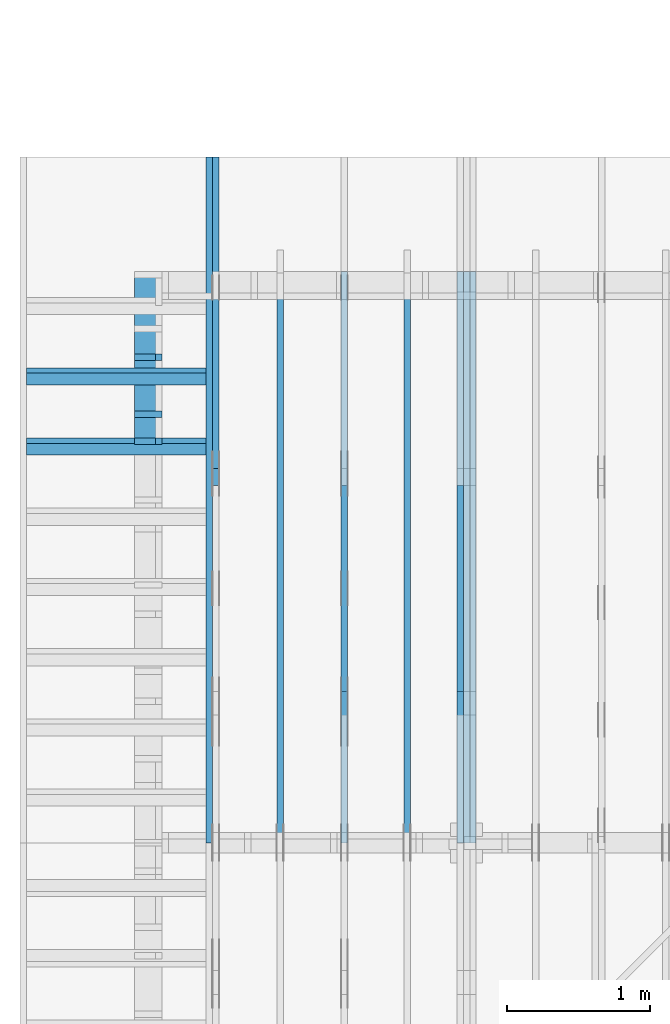
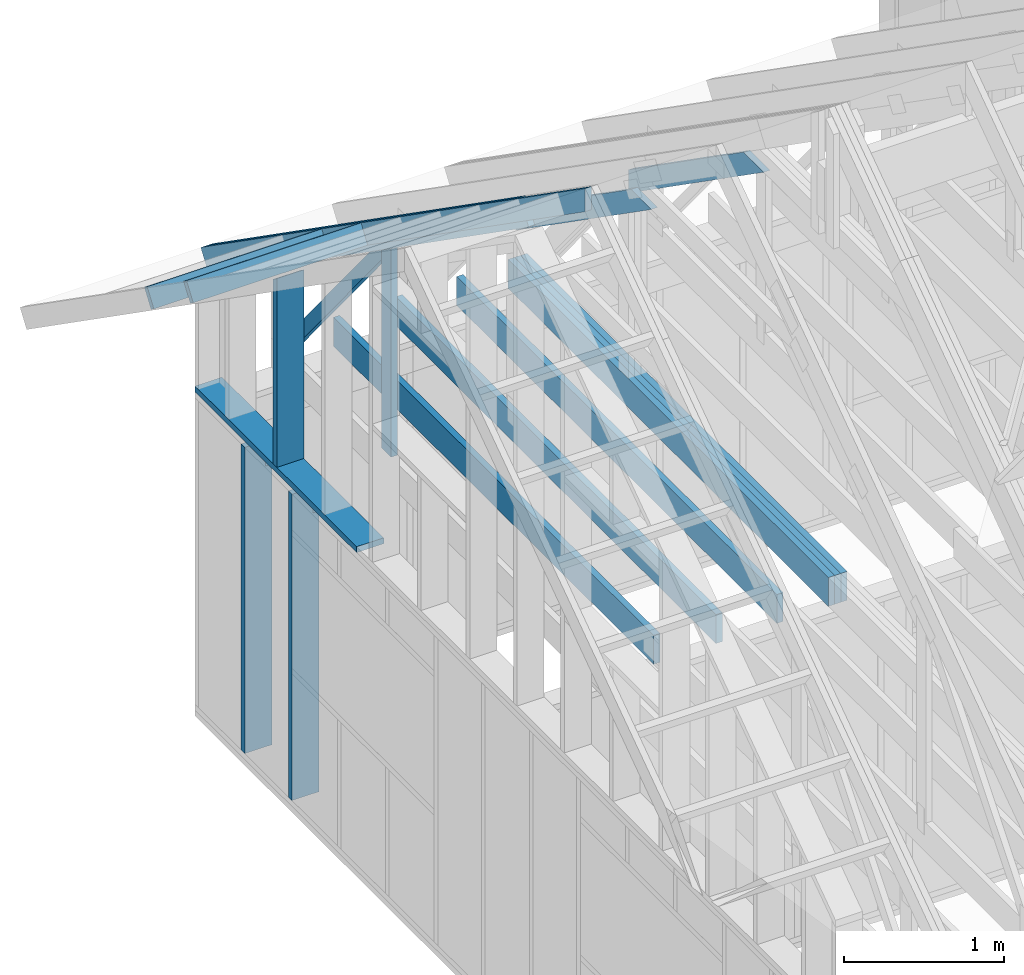
# One storey, part 13 of 70: 18 members, 8 elements without a shape of their own.
"""IFC2X3 building model written with IfcOpenShell, lengths in millimetres."""

from ifc_helpers import new_model, si_unit, frame, origin, origin_with_axes, origin_2d, place, context, project, spatial, faceted_brep, element, aggregate, save


model = new_model("IFC2X3")

# Units and contexts
model_context = context("Model", 3, precision=1e-05, world=origin())
plan_context = context("Plan", 2, precision=1e-05, world=origin_2d())
ifc_project = project(units=[si_unit("LENGTHUNIT", "METRE", prefix="MILLI"), si_unit("AREAUNIT", "SQUARE_METRE"), si_unit("VOLUMEUNIT", "CUBIC_METRE"), si_unit("SOLIDANGLEUNIT", "STERADIAN"), si_unit("PLANEANGLEUNIT", "RADIAN"), si_unit("MASSUNIT", "GRAM"), si_unit("TIMEUNIT", "SECOND"), si_unit("THERMODYNAMICTEMPERATUREUNIT", "DEGREE_CELSIUS"), si_unit("LUMINOUSINTENSITYUNIT", "LUMEN")], contexts=[model_context, plan_context])

# Site, building, storey
site_placement = place(None, origin_with_axes())
site = spatial("IfcSite", under=ifc_project, at=site_placement, CompositionType="ELEMENT")
building_placement = place(site_placement, origin_with_axes())
building = spatial("IfcBuilding", under=site, at=building_placement, Name="Layout 1", CompositionType="ELEMENT")
storey_placement = place(building_placement, origin_with_axes())
storey = spatial("IfcBuildingStorey", under=building, at=storey_placement, Name="Storey 1", CompositionType="ELEMENT", Elevation=0.0)

# Assembly, members
assembly_1_placement = place(storey_placement, frame((1969.9999999999982, 8000.000000000001, 1.1021457184401395e-14), z_axis=(-1.0, 1.836909530733566e-16, 6.123031769111886e-17), x_axis=(-1.836909530733566e-16, -1.0, 0.0)))
assembly_1 = element("IfcElementAssembly", 1, at=assembly_1_placement, inside=storey, Name="T11", AssemblyPlace="FACTORY", PredefinedType="TRUSS")
member_1_placement = place(assembly_1_placement, frame((3999.9999999999995, 219.99999999999994, -90.0), z_axis=(0.0, 0.0, 1.0), x_axis=(-1.0, 1.2246063538223773e-16, 0.0)))
member_1 = element("IfcMember", 2, at=member_1_placement, Name="B3", context=model_context, shape_type="Brep", body=[
    faceted_brep([(3999.9999999999995, 220.00000000000043, 45.0), (0.0, 220.00000000000043, 45.0), (0.0, 0.0, 45.0), (4000.0, 0.0, 45.0), (0.0, 220.00000000000043, 0.0), (3999.9999999999995, 220.00000000000043, 4.898425415289508e-13), (4000.0, 0.0, 4.898425415289509e-13), (0.0, 0.0, 0.0), (0.0, 0.0, 0.0), (2.755364296100349e-15, -3.3742366240998092e-31, 45.0), (2.969670408019265e-14, 220.0, 45.0), (2.69413397840923e-14, 220.0, -1.6496267940043512e-30), (4000.0, -7.347638122934264e-13, 7.109387612088872e-29), (4000.0, -7.32008447997326e-13, 45.0), (5.061354936149714e-31, 2.755364296100349e-15, 45.0), (0.0, 0.0, 0.0), (4000.0, 220.00000000000043, 5.048709793414476e-29), (4000.0, 220.00000000000043, 45.0), (4000.0, 4.263256414560601e-13, 45.0), (4000.0, 4.263256414560601e-13, 0.0), (0.0, 220.0, 0.0), (0.0, 220.0, 45.0), (3999.9999999999995, 220.00000000000065, 45.0), (3999.9999999999995, 220.00000000000065, 1.262177448353619e-29)], [[[0, 1, 2, 3]], [[4, 5, 6, 7]], [[8, 9, 10, 11]], [[12, 13, 14, 15]], [[16, 17, 18, 19]], [[20, 21, 22, 23]]]),
])
member_2_placement = place(assembly_1_placement, frame((3999.9999999999995, 219.99999999999994, -135.0), z_axis=(0.0, 0.0, 1.0), x_axis=(-1.0, 1.2246063538223773e-16, 0.0)))
member_2 = element("IfcMember", 3, at=member_2_placement, Name="B3", context=model_context, shape_type="Brep", body=[
    faceted_brep([(3999.9999999999995, 220.00000000000043, 45.0), (0.0, 220.00000000000043, 45.0), (0.0, 0.0, 45.0), (4000.0, 0.0, 45.0), (0.0, 220.00000000000043, 0.0), (3999.9999999999995, 220.00000000000043, 4.898425415289508e-13), (4000.0, 0.0, 4.898425415289509e-13), (0.0, 0.0, 0.0), (0.0, 0.0, 0.0), (2.755364296100349e-15, -3.3742366240998092e-31, 45.0), (2.969670408019265e-14, 220.0, 45.0), (2.69413397840923e-14, 220.0, -1.6496267940043512e-30), (4000.0, -7.347638122934264e-13, 7.109387612088872e-29), (4000.0, -7.32008447997326e-13, 45.0), (5.061354936149714e-31, 2.755364296100349e-15, 45.0), (0.0, 0.0, 0.0), (4000.0, 220.00000000000043, 5.048709793414476e-29), (4000.0, 220.00000000000043, 45.0), (4000.0, 4.263256414560601e-13, 45.0), (4000.0, 4.263256414560601e-13, 0.0), (0.0, 220.0, 0.0), (0.0, 220.0, 45.0), (3999.9999999999995, 220.00000000000065, 45.0), (3999.9999999999995, 220.00000000000065, 1.262177448353619e-29)], [[[0, 1, 2, 3]], [[4, 5, 6, 7]], [[8, 9, 10, 11]], [[12, 13, 14, 15]], [[16, 17, 18, 19]], [[20, 21, 22, 23]]]),
])
member_3_placement = place(assembly_1_placement, frame((3999.9999999999995, 219.99999999999994, -180.0), z_axis=(0.0, 0.0, 1.0), x_axis=(-1.0, 1.2246063538223773e-16, 0.0)))
member_3 = element("IfcMember", 4, at=member_3_placement, Name="B3", context=model_context, shape_type="Brep", body=[
    faceted_brep([(3999.9999999999995, 220.00000000000043, 45.0), (0.0, 220.00000000000043, 45.0), (0.0, 0.0, 45.0), (4000.0, 0.0, 45.0), (0.0, 220.00000000000043, 0.0), (3999.9999999999995, 220.00000000000043, 4.898425415289508e-13), (4000.0, 0.0, 4.898425415289509e-13), (0.0, 0.0, 0.0), (0.0, 0.0, 0.0), (2.755364296100349e-15, -3.3742366240998092e-31, 45.0), (2.969670408019265e-14, 220.0, 45.0), (2.69413397840923e-14, 220.0, -1.6496267940043512e-30), (4000.0, -7.347638122934264e-13, 7.109387612088872e-29), (4000.0, -7.32008447997326e-13, 45.0), (5.061354936149714e-31, 2.755364296100349e-15, 45.0), (0.0, 0.0, 0.0), (4000.0, 220.00000000000043, 5.048709793414476e-29), (4000.0, 220.00000000000043, 45.0), (4000.0, 4.263256414560601e-13, 45.0), (4000.0, 4.263256414560601e-13, 0.0), (0.0, 220.0, 0.0), (0.0, 220.0, 45.0), (3999.9999999999995, 220.00000000000065, 45.0), (3999.9999999999995, 220.00000000000065, 1.262177448353619e-29)], [[[0, 1, 2, 3]], [[4, 5, 6, 7]], [[8, 9, 10, 11]], [[12, 13, 14, 15]], [[16, 17, 18, 19]], [[20, 21, 22, 23]]]),
])
member_4_placement = place(assembly_1_placement, frame((1500.0000000016348, 1635.2479471379418, -90.0), z_axis=(0.0, 0.0, 1.0), x_axis=(0.8191520442886182, 0.57357643635158, 0.0)))
member_4 = element("IfcMember", 5, at=member_4_placement, Name="SC5", context=model_context, shape_type="Brep", body=[
    faceted_brep([(1858.470709186502, 144.99999999999932, 45.0), (101.53009304079887, 144.99999999999932, 45.0), (0.0, 8.753886504564434e-12, 45.0), (2065.5521701640737, 8.753886504564434e-12, 45.0), (101.53009304079887, 144.99999999999932, 1.2433439704193942e-14), (1858.470709186502, 144.99999999999932, 2.27589503886257e-13), (2065.5521701640737, 8.753886504564434e-12, 2.529488311734525e-13), (0.0, 8.753886504564434e-12, 0.0), (3.760981837651581e-15, 8.751253036730632e-12, -2.8112743459008187e-31), (6.0180441335604696e-15, 8.749672624696822e-12, 45.0), (101.53009304079885, 145.00000000001066, 45.0), (101.53009304079885, 145.00000000001066, 1.0796763268234844e-30), (2065.5521701640737, 1.0361478085862912e-12, -6.344365949469521e-29), (2065.5521701640737, 1.0389031728823915e-12, 45.0), (1.0295155918449194e-29, 8.756641868860535e-12, 45.0), (0.0, 8.753886504564434e-12, 0.0), (1858.470709186502, 144.9999999999992, 1.262177448353619e-29), (1858.470709186502, 144.9999999999992, 45.0), (2065.5521701640737, 0.0, 45.0), (2065.5521701640737, 0.0, 1.262177448353619e-29), (101.53009304079887, 145.0000000000107, -1.5777218104420236e-30), (101.53009304079887, 145.0000000000107, 45.0), (1858.470709186502, 144.99999999999926, 45.0), (1858.470709186502, 144.99999999999926, -4.733165431326071e-30)], [[[0, 1, 2, 3]], [[4, 5, 6, 7]], [[8, 9, 10, 11]], [[12, 13, 14, 15]], [[16, 17, 18, 19]], [[20, 21, 22, 23]]]),
])
aggregate(assembly_1, [member_1, member_2, member_3, member_4])

assembly_2_placement = place(storey_placement, frame((304.9999999999989, 8000.000000000001, 1.3776821480501744e-15), z_axis=(-1.0, 1.836909530733566e-16, 6.123031769111886e-17), x_axis=(-1.836909530733566e-16, -1.0, 0.0)))
assembly_2 = element("IfcElementAssembly", 6, at=assembly_2_placement, inside=storey, Name="T2", AssemblyPlace="FACTORY", PredefinedType="TRUSS")
member_5_placement = place(assembly_2_placement, frame((-688.1525949112561, 280.09932079516193, -45.0), z_axis=(0.0, 0.0, 1.0), x_axis=(0.8191520442889915, 0.5735764363510465, 0.0)))
member_5 = element("IfcMember", 7, at=member_5_placement, Name="T9", context=model_context, shape_type="Brep", body=[
    faceted_brep([(4768.153825500821, 195.00000000307512, 45.0), (0.0, 195.00000000307512, 45.0), (3.9244696381501853e-10, 0.0, 45.0), (4768.153825500451, 0.0, 45.0), (0.0, 195.00000000307512, 0.0), (4768.153825500821, 195.00000000307512, 5.83911147071078e-13), (4768.153825500451, 0.0, 5.839111470710327e-13), (3.9244696381501853e-10, 0.0, 4.805930454261723e-26), (3.9244696381501853e-10, 0.0, 0.0), (3.9244971917931464e-10, 5.545142646990014e-27, 45.0), (1.4200689302868088e-14, 195.00000000050534, 45.0), (1.1445325006767739e-14, 195.00000000050534, -7.008008862414939e-31), (4768.153825500451, 3.103358117890669e-09, 2.4874127547680185e-29), (4768.153825500451, 3.103360873254965e-09, 45.0), (3.9244696381501853e-10, 2.755364296066913e-15, 45.0), (3.9244696381501853e-10, -3.343582626433149e-26, 2.04728626443068e-42), (4768.153825500451, 195.00000000307512, -2.2668706972430995e-26), (4768.153825500451, 195.00000000307512, 45.0), (4768.153825500451, 3.1037643566378392e-09, 45.0), (4768.153825500451, 3.1037643566378392e-09, 0.0), (0.0, 195.00000000050534, 0.0), (0.0, 195.00000000050534, 45.0), (4768.153825500821, 195.0000000030746, 45.0), (4768.153825500821, 195.0000000030746, -2.997671439839845e-29)], [[[0, 1, 2, 3]], [[4, 5, 6, 7]], [[8, 9, 10, 11]], [[12, 13, 14, 15]], [[16, 17, 18, 19]], [[20, 21, 22, 23]]]),
])
member_6_placement = place(assembly_2_placement, frame((1380.0000000018192, 1812.2602625085638, -45.0), z_axis=(0.0, 0.0, 1.0), x_axis=(-1.836909530733566e-16, -1.0, 0.0)))
member_6 = element("IfcMember", 8, at=member_6_placement, Name="R1", context=model_context, shape_type="Brep", body=[
    faceted_brep([(1592.2602625085638, 120.00000000001455, 45.0), (0.0, 120.00000000001455, 45.0), (84.02490458526881, 1.432454155292362e-11, 45.0), (1592.2602625085638, 1.432454155292362e-11, 45.0), (0.0, 120.00000000001455, 0.0), (1592.2602625085638, 120.00000000001455, 1.9498920344068735e-13), (1592.2602625085638, 1.432454155292362e-11, 1.9498920344068735e-13), (84.02490458526881, 1.432454155292362e-11, 1.0289743203443919e-14), (84.0249045852688, 1.4303225270850817e-11, 1.5777218104420236e-30), (84.02490458526881, 1.4303225270850817e-11, 45.0), (2.1316282072803006e-14, 120.00000000001435, 45.0), (2.1316282072803006e-14, 120.00000000001435, -2.3665827156630354e-30), (1592.2602625085638, -7.262347142616226e-13, 4.446758227255812e-29), (1592.2602625085638, -7.234793499655223e-13, 45.0), (84.02490458526881, 1.4288972904488156e-11, 45.0), (84.02490458526881, 1.4286217540192056e-11, 2.3465914747521543e-30), (1592.2602625085638, 120.00000000001455, 0.0), (1592.2602625085638, 120.00000000001455, 45.0), (1592.2602625085638, 0.0, 45.0), (1592.2602625085638, 0.0, 0.0), (0.0, 120.00000000001432, 0.0), (0.0, 120.00000000001432, 45.0), (1592.2602625085638, 120.00000000001458, 45.0), (1592.2602625085638, 120.00000000001458, 1.5777218104420236e-30)], [[[0, 1, 2, 3]], [[4, 5, 6, 7]], [[8, 9, 10, 11]], [[12, 13, 14, 15]], [[16, 17, 18, 19]], [[20, 21, 22, 23]]]),
])
member_7_placement = place(assembly_2_placement, frame((1343.2488450148448, 1758.3285898386946, -45.0), z_axis=(0.0, 0.0, 1.0), x_axis=(-0.6335417245359891, -0.7737085260432154, 0.0)))
member_7 = element("IfcMember", 9, at=member_7_placement, Name="W7", context=model_context, shape_type="Brep", body=[
    faceted_brep([(1910.463793861842, 95.00000000000107, 45.0), (58.00905222783058, 95.00000000000107, 45.0), (0.0, 47.49999999991742, 45.0), (169.12158093119842, 1.5489831639570184e-12, 45.0), (1891.3495332830453, 1.5489831639570184e-12, 45.0), (1949.3585855093759, 47.49999999991742, 45.0), (58.00905222783058, 95.00000000000107, 7.103825393741545e-15), (1910.463793861842, 95.00000000000107, 2.3395661007108163e-13), (1949.3585855093759, 47.49999999991742, 2.3871969096929837e-13), (1891.3495332830453, 1.5489831639570184e-12, 2.316158655757405e-13), (169.12158093119842, 1.5489831639570184e-12, 2.0710736257683097e-14), (0.0, 47.49999999991742, 0.0), (7.105427357601002e-15, 47.49999999991742, -1.8546386070166963e-31), (7.105427357601002e-15, 47.499999999917414, 45.0), (58.009052227830594, 95.0000000000011, 45.0), (58.009052227830594, 95.0000000000011, -1.0419654606573396e-30), (169.12158093119845, 1.5489831639570184e-12, -3.944304526105059e-31), (169.12158093119845, 1.5489831639570184e-12, 45.0), (0.0, 47.49999999991742, 45.0), (0.0, 47.49999999991742, -3.944304526105059e-31), (1891.3495332830453, -3.2618741015423187e-13, 1.9972558750586918e-29), (1891.3495332830453, -3.234320458581315e-13, 45.0), (169.12158093119842, 1.5225713492022007e-12, 45.0), (169.12158093119842, 1.5198159849061003e-12, 1.785915639441465e-30), (1949.3585855093754, 47.4999999985622, -4.7346005356158474e-29), (1949.3585855093754, 47.4999999985622, 45.0), (1891.349533283045, 5.684341886080801e-13, 45.0), (1891.349533283045, 5.684341886080801e-13, -3.426215972529022e-29), (1910.4637938618428, 95.00000000000102, 3.224996634343783e-29), (1910.4637938618428, 95.00000000000102, 45.0), (1949.3585855093766, 47.49999999856175, 45.0), (1949.3585855093766, 47.49999999856175, 3.2628327627696677e-29), (58.00905222783058, 95.0000000000011, 0.0), (58.00905222783058, 95.0000000000011, 45.0), (1910.463793861842, 95.00000000000098, 45.0), (1910.463793861842, 95.00000000000098, -5.5220263365470826e-30)], [[[0, 1, 2, 3, 4, 5]], [[6, 7, 8, 9, 10, 11]], [[12, 13, 14, 15]], [[16, 17, 18, 19]], [[20, 21, 22, 23]], [[24, 25, 26, 27]], [[28, 29, 30, 31]], [[32, 33, 34, 35]]]),
])
aggregate(assembly_2, [member_5, member_6, member_7])

assembly_3_placement = place(storey_placement, frame((1204.9999999999989, 8000.000000000001, 1.3776821480501744e-15), z_axis=(-1.0, 1.836909530733566e-16, 6.123031769111886e-17), x_axis=(-1.836909530733566e-16, -1.0, 0.0)))
assembly_3 = element("IfcElementAssembly", 10, at=assembly_3_placement, inside=storey, Name="T2", AssemblyPlace="FACTORY", PredefinedType="TRUSS")
member_8_placement = place(assembly_3_placement, frame((3999.9999999999995, 220.0, -45.0), z_axis=(0.0, 0.0, 1.0), x_axis=(-1.0, 1.2246063538223773e-16, 0.0)))
member_8 = element("IfcMember", 11, at=member_8_placement, Name="B3", context=model_context, shape_type="Brep", body=[
    faceted_brep([(3999.9999999999995, 220.00000000000048, 45.0), (0.0, 220.00000000000048, 45.0), (0.0, 0.0, 45.0), (4000.0, 0.0, 45.0), (0.0, 220.00000000000048, 0.0), (3999.9999999999995, 220.00000000000048, 4.898425415289508e-13), (4000.0, 0.0, 4.898425415289509e-13), (0.0, 0.0, 0.0), (0.0, 0.0, 0.0), (2.755364296100349e-15, -3.3742366240998092e-31, 45.0), (2.969670408019265e-14, 220.0, 45.0), (2.69413397840923e-14, 220.0, -1.6496267940043512e-30), (4000.0, -7.347638122934264e-13, 7.457441671638533e-29), (4000.0, -7.32008447997326e-13, 45.0), (5.061354936149714e-31, 2.755364296100349e-15, 45.0), (0.0, 0.0, 0.0), (4000.0, 220.00000000000048, 5.048709793414476e-29), (4000.0, 220.00000000000048, 45.0), (4000.0, 4.831690603168681e-13, 45.0), (4000.0, 4.831690603168681e-13, 0.0), (0.0, 220.0, 0.0), (0.0, 220.0, 45.0), (3999.9999999999995, 220.00000000000065, 45.0), (3999.9999999999995, 220.00000000000065, 9.466330862652142e-30)], [[[0, 1, 2, 3]], [[4, 5, 6, 7]], [[8, 9, 10, 11]], [[12, 13, 14, 15]], [[16, 17, 18, 19]], [[20, 21, 22, 23]]]),
])
member_9_placement = place(assembly_3_placement, frame((1500.0000000042137, 1635.2479181251456, -45.0), z_axis=(0.0, 0.0, 1.0), x_axis=(0.8191520442886182, 0.57357643635158, 0.0)))
member_9 = element("IfcMember", 12, at=member_9_placement, Name="SC5", context=model_context, shape_type="Brep", body=[
    faceted_brep([(1858.4707597648467, 145.0000000027453, 45.0), (101.53009304262741, 145.0000000027453, 45.0), (0.0, 4.505750439420808e-09, 45.0), (2065.552220746341, 4.505750439420808e-09, 45.0), (101.53009304262741, 145.0000000027453, 1.2433439704417867e-14), (1858.4707597648467, 145.0000000027453, 2.275895100801132e-13), (2065.552220746341, 4.505750439420808e-09, 2.5294883736778907e-13), (0.0, 4.505750439420808e-09, 0.0), (5.1128441160023706e-15, 4.505746859368817e-09, -3.82176998409612e-31), (7.369906411908836e-15, 4.505745278956782e-09, 45.0), (101.5300930426274, 145.0000000071184, 45.0), (101.5300930426274, 145.0000000071184, 1.224891444630282e-30), (2065.552220746341, -3.5477999352162224e-13, 2.172329171380478e-29), (2065.552220746341, -3.520246292255219e-13, 45.0), (6.010964676742231e-27, 4.505753194785104e-09, 45.0), (0.0, 4.505750439420808e-09, 0.0), (1858.4707597648467, 145.0000000027453, -1.262177448353619e-29), (1858.4707597648467, 145.0000000027453, 45.0), (2065.552220746341, 1.1368683772161603e-13, 45.0), (2065.552220746341, 1.1368683772161603e-13, -1.262177448353619e-29), (101.53009304262741, 145.0000000071184, 0.0), (101.53009304262741, 145.0000000071184, 45.0), (1858.4707597648467, 145.00000000274542, 45.0), (1858.4707597648467, 145.00000000274542, 6.310887241768095e-30)], [[[0, 1, 2, 3]], [[4, 5, 6, 7]], [[8, 9, 10, 11]], [[12, 13, 14, 15]], [[16, 17, 18, 19]], [[20, 21, 22, 23]]]),
])
aggregate(assembly_3, [member_8, member_9])

# Assembly, member
assembly_4_placement = place(storey_placement, frame((754.9999999999991, 8000.000000000001, 1.3776821480501744e-15), z_axis=(-1.0, 1.836909530733566e-16, 6.123031769111886e-17), x_axis=(-1.836909530733566e-16, -1.0, 0.0)))
assembly_4 = element("IfcElementAssembly", 13, at=assembly_4_placement, inside=storey, Name="MB1", AssemblyPlace="FACTORY", PredefinedType="TRUSS")
member_10_placement = place(assembly_4_placement, frame((4000.0000000000005, 219.99999999999997, -45.0), z_axis=(0.0, 0.0, 1.0), x_axis=(-1.0, 1.2246063538223773e-16, 0.0)))
member_10 = element("IfcMember", 14, at=member_10_placement, Name="B3", context=model_context, shape_type="Brep", body=[
    faceted_brep([(4000.0000000000005, 220.00000000000045, 45.0), (0.0, 220.00000000000045, 45.0), (0.0, 0.0, 45.0), (4000.0000000000005, 0.0, 45.0), (0.0, 220.00000000000045, 0.0), (4000.0000000000005, 220.00000000000045, 4.89842541528951e-13), (4000.0000000000005, 0.0, 4.89842541528951e-13), (0.0, 0.0, 0.0), (0.0, 0.0, 0.0), (2.755364296100349e-15, -3.3742366240998092e-31, 45.0), (2.969670408019265e-14, 220.0, 45.0), (2.69413397840923e-14, 220.0, -1.6496267940043512e-30), (4000.0000000000005, -7.347638122934265e-13, 7.283414641863702e-29), (4000.0000000000005, -7.320084479973261e-13, 45.0), (5.061354936149714e-31, 2.755364296100349e-15, 45.0), (0.0, 0.0, 0.0), (4000.0000000000005, 220.00000000000045, 0.0), (4000.0000000000005, 220.00000000000045, 45.0), (4000.0000000000005, 4.547473508864641e-13, 45.0), (4000.0000000000005, 4.547473508864641e-13, 0.0), (0.0, 220.0, 0.0), (0.0, 220.0, 45.0), (4000.0000000000005, 220.00000000000065, 45.0), (4000.0000000000005, 220.00000000000065, 1.1044052673094165e-29)], [[[0, 1, 2, 3]], [[4, 5, 6, 7]], [[8, 9, 10, 11]], [[12, 13, 14, 15]], [[16, 17, 18, 19]], [[20, 21, 22, 23]]]),
])
aggregate(assembly_4, [member_10])

assembly_5_placement = place(storey_placement, frame((1643.7499999999982, 8000.000000000001, 1.3776821480501744e-15), z_axis=(-1.0, 1.836909530733566e-16, 6.123031769111886e-17), x_axis=(-1.836909530733566e-16, -1.0, 0.0)))
assembly_5 = element("IfcElementAssembly", 15, at=assembly_5_placement, inside=storey, Name="MB1", AssemblyPlace="FACTORY", PredefinedType="TRUSS")
member_11_placement = place(assembly_5_placement, frame((4000.0000000000005, 219.99999999999997, -45.0), z_axis=(0.0, 0.0, 1.0), x_axis=(-1.0, 1.2246063538223773e-16, 0.0)))
member_11 = element("IfcMember", 16, at=member_11_placement, Name="B3", context=model_context, shape_type="Brep", body=[
    faceted_brep([(4000.0000000000005, 220.00000000000045, 45.0), (0.0, 220.00000000000045, 45.0), (0.0, 0.0, 45.0), (4000.0000000000005, 0.0, 45.0), (0.0, 220.00000000000045, 0.0), (4000.0000000000005, 220.00000000000045, 4.89842541528951e-13), (4000.0000000000005, 0.0, 4.89842541528951e-13), (0.0, 0.0, 0.0), (0.0, 0.0, 0.0), (2.755364296100349e-15, -3.3742366240998092e-31, 45.0), (2.969670408019265e-14, 220.0, 45.0), (2.69413397840923e-14, 220.0, -1.6496267940043512e-30), (4000.0000000000005, -7.347638122934265e-13, 7.283414641863702e-29), (4000.0000000000005, -7.320084479973261e-13, 45.0), (5.061354936149714e-31, 2.755364296100349e-15, 45.0), (0.0, 0.0, 0.0), (4000.0000000000005, 220.00000000000045, 0.0), (4000.0000000000005, 220.00000000000045, 45.0), (4000.0000000000005, 4.547473508864641e-13, 45.0), (4000.0000000000005, 4.547473508864641e-13, 0.0), (0.0, 220.0, 0.0), (0.0, 220.0, 45.0), (4000.0000000000005, 220.00000000000065, 45.0), (4000.0000000000005, 220.00000000000065, 1.1044052673094165e-29)], [[[0, 1, 2, 3]], [[4, 5, 6, 7]], [[8, 9, 10, 11]], [[12, 13, 14, 15]], [[16, 17, 18, 19]], [[20, 21, 22, 23]]]),
])
aggregate(assembly_5, [member_11])

# Assembly, members
assembly_6_placement = place(storey_placement, frame((-243.55339059327574, 8000.000000000001, -2470.0), z_axis=(-1.0, 1.836909530733566e-16, 6.123031769111886e-17), x_axis=(-1.836909530733566e-16, -1.0, 0.0)))
assembly_6 = element("IfcElementAssembly", 17, at=assembly_6_placement, inside=storey, Name="VE3", AssemblyPlace="FACTORY", PredefinedType="NOTDEFINED")
member_12_placement = place(assembly_6_placement, frame((577.5000000018335, 2425.0, -195.0), z_axis=(0.0, 0.0, 1.0), x_axis=(-1.836909530733566e-16, -1.0, 0.0)))
member_12 = element("IfcMember", 18, at=member_12_placement, Name="S11", context=model_context, shape_type="Brep", body=[
    faceted_brep([(0.0, 44.99999999998545, 45.0), (195.00000000186265, 44.99999999998545, 45.00000000000002), (195.00000000186265, 0.0, 45.00000000000002), (0.0, 0.0, 45.0), (195.00000000186265, 0.0, 0.0), (195.00000000186265, -3.3742366240998092e-31, 45.0), (195.00000000186265, 44.99999999998545, 45.0), (195.00000000186265, 44.99999999998545, 0.0), (2.755364296100349e-15, -3.3742366240998092e-31, 45.0), (1.1939911949768178e-14, -1.462169203776584e-30, 195.0), (1.7450640541967096e-14, 44.99999999998545, 195.00000000000003), (8.266092888299264e-15, 44.99999999998545, 45.0), (2335.0, -4.2891837542628763e-13, 2.626280839091018e-29), (2335.0, -4.1697846347651946e-13, 195.0), (2.193253805664876e-30, 1.1939911949768178e-14, 195.0), (5.061354936149714e-31, 2.755364296100349e-15, 45.0), (195.00000000186265, -3.306437155354634e-14, 45.0), (195.00000000186265, -3.5819735849646686e-14, 2.193253805685826e-30), (-1.6871183120499046e-31, 44.99999999998545, 45.0), (-7.31084601888292e-31, 44.999999999985434, 195.0), (2335.0, 44.99999999998529, 195.0), (2335.0, 44.999999999985306, -1.5777218104420236e-29), (195.00000000186265, 44.999999999985434, -7.888609052210118e-31), (195.00000000186265, 44.999999999985434, 45.0), (2335.0, 44.9999999999859, 2.842170943040401e-14), (2335.0, 44.9999999999859, 195.0), (2335.0, 4.547473508864641e-13, 195.0), (2335.0, 4.547473508864641e-13, 0.0), (2335.0, 44.9999999999859, 195.0), (0.0, 44.9999999999859, 195.0), (0.0, 0.0, 195.0), (2335.0, 0.0, 195.0), (195.00000000186265, 44.99999999998545, 2.3879823899764457e-14), (2335.0, 44.99999999998545, 2.859455836175251e-13), (2335.0, 4.547473508864641e-13, 2.859455836175251e-13), (195.00000000186265, 4.547473508864641e-13, 2.3879823899764457e-14)], [[[0, 1, 2, 3]], [[4, 5, 6, 7]], [[8, 9, 10, 11]], [[12, 13, 14, 15, 16, 17]], [[18, 19, 20, 21, 22, 23]], [[24, 25, 26, 27]], [[28, 29, 30, 31]], [[32, 33, 34, 35]]]),
])
member_13_placement = place(assembly_6_placement, frame((1167.5000000036384, 2425.0, -195.0), z_axis=(0.0, 0.0, 1.0), x_axis=(-1.836909530733566e-16, -1.0, 0.0)))
member_13 = element("IfcMember", 19, at=member_13_placement, Name="S11", context=model_context, shape_type="Brep", body=[
    faceted_brep([(0.0, 45.0000000000141, 45.0), (195.00000000186265, 45.0000000000141, 45.00000000000002), (195.00000000186265, 1.4097167877480388e-11, 45.00000000000002), (0.0, 1.4097167877480388e-11, 45.0), (195.00000000186265, 1.2960299500264227e-11, 0.0), (195.00000000186265, 1.2960299500264227e-11, 45.0), (195.00000000186265, 45.000000000015234, 45.0), (195.00000000186265, 45.000000000015234, 0.0), (2.7553642961020753e-15, 1.4097167877480388e-11, 45.0), (1.1939911949769904e-14, 1.4097167877480388e-11, 195.0), (1.7450640541970602e-14, 45.0000000000141, 195.0), (8.266092888302773e-15, 45.0000000000141, 45.0), (2335.0, 1.36682495020541e-11, 2.626280839091018e-29), (2335.0, 1.3680189414003868e-11, 195.0), (2.193253805664876e-30, 1.4109107789430156e-11, 195.0), (5.061354936149714e-31, 1.4099923241776488e-11, 45.0), (195.00000000186265, 1.4064103505926841e-11, 45.0), (195.00000000186265, 1.406134814163074e-11, 2.193253805685862e-30), (-1.6871183120499046e-31, 45.000000000015234, 45.0), (-7.31084601888292e-31, 45.00000000001522, 195.0), (2335.0, 45.00000000001508, 195.0), (2335.0, 45.00000000001509, -8.67746995743113e-30), (195.00000000186265, 45.00000000001522, -7.888609052210118e-31), (195.00000000186265, 45.00000000001522, 45.0), (2335.0, 45.000000000029104, 0.0), (2335.0, 45.000000000029104, 195.0), (2335.0, 0.0, 195.0), (2335.0, 0.0, 0.0), (2335.0, 45.000000000029104, 195.0), (0.0, 45.000000000029104, 195.0), (0.0, 1.4097167877480388e-11, 195.0), (2335.0, 1.4097167877480388e-11, 195.0), (195.00000000186265, 45.000000000015234, 2.3879823899764457e-14), (2335.0, 45.000000000015234, 2.859455836175251e-13), (2335.0, 0.0, 2.859455836175251e-13), (195.00000000186265, 0.0, 2.3879823899764457e-14)], [[[0, 1, 2, 3]], [[4, 5, 6, 7]], [[8, 9, 10, 11]], [[12, 13, 14, 15, 16, 17]], [[18, 19, 20, 21, 22, 23]], [[24, 25, 26, 27]], [[28, 29, 30, 31]], [[32, 33, 34, 35]]]),
])
aggregate(assembly_6, [member_12, member_13])

assembly_7_placement = place(storey_placement, frame((-48.55339059327645, 2.2546681725408788e-11, 1.1939911949768178e-14), z_axis=(1.0, 1.156240088482502e-13, 6.123031769111886e-17), x_axis=(-1.156240088482502e-13, 1.0, 0.0)))
assembly_7 = element("IfcElementAssembly", 20, at=assembly_7_placement, inside=storey, Name="VEg1", AssemblyPlace="FACTORY", PredefinedType="NOTDEFINED")
member_14_placement = place(assembly_7_placement, frame((8000.000000000001, 45.0, -195.0), z_axis=(0.0, 0.0, 1.0), x_axis=(-1.0, 1.2246063538223773e-16, 0.0)))
member_14 = element("IfcMember", 21, at=member_14_placement, Name="P11", context=model_context, shape_type="Brep", body=[
    faceted_brep([(2019.99999999999, 45.00000000000025, 195.0), (0.0, 45.00000000000025, 195.0), (0.0, 0.0, 195.0), (2019.99999999999, 0.0, 195.0), (0.0, 45.00000000000025, 0.0), (2019.99999999999, 45.00000000000025, 2.47370483472119e-13), (2019.99999999999, 0.0, 2.47370483472119e-13), (0.0, 0.0, 0.0), (0.0, 0.0, 0.0), (1.1939911949768178e-14, -1.462169203776584e-30, 195.0), (1.7450640541968876e-14, 45.0, 195.0), (5.510728592200698e-15, 45.0, -3.3742366240998092e-31), (2019.99999999999, -3.710557252081785e-13, 3.794722504090295e-29), (2019.99999999999, -3.591158132584103e-13, 195.0), (2.193253805664876e-30, 1.1939911949768178e-14, 195.0), (0.0, 0.0, 0.0), (2019.99999999999, 45.00000000000025, 0.0), (2019.99999999999, 45.00000000000025, 195.0), (2019.99999999999, 2.4868995751603507e-13, 195.0), (2019.99999999999, 2.4868995751603507e-13, 0.0), (0.0, 45.0, 0.0), (1.5777218104420236e-30, 44.999999999999986, 195.0), (2019.99999999999, 45.00000000000031, 195.0), (2019.99999999999, 45.00000000000033, 4.338734978715565e-30)], [[[0, 1, 2, 3]], [[4, 5, 6, 7]], [[8, 9, 10, 11]], [[12, 13, 14, 15]], [[16, 17, 18, 19]], [[20, 21, 22, 23]]]),
])
member_15_placement = place(assembly_7_placement, frame((7022.500000008266, 45.0, -195.0), z_axis=(0.0, 0.0, 1.0), x_axis=(-8.269481020090064e-16, 1.0, 0.0)))
member_15 = element("IfcMember", 22, at=member_15_placement, Name="S20", context=model_context, shape_type="Brep", body=[
    faceted_brep([(1439.01503594876, 45.0, 195.0), (3.552713678800501e-14, 45.0, 195.0), (0.0, 9.094947017729282e-13, 195.0), (1407.505696729313, 9.094947017729282e-13, 195.0), (3.552713678800501e-14, 45.0, 4.350675744370766e-30), (1439.01503594876, 45.0, 1.7622269562687881e-13), (1407.505696729313, 9.094947017729282e-13, 1.7236404192559088e-13), (0.0, 9.094947017729282e-13, 0.0), (2.06040607682413e-28, 9.094947017729282e-13, -1.2615931865665335e-44), (1.1939911949768385e-14, 9.094947017729282e-13, 195.0), (5.741866942847471e-14, 45.00000000000091, 195.0), (4.547875747870654e-14, 45.00000000000091, -6.093408964331665e-31), (1407.505696729313, -5.99167546555423e-13, 3.6687219225796807e-29), (1407.505696729313, -5.872276346056548e-13, 195.0), (1.2798025932568618e-29, 9.214346137226964e-13, 195.0), (0.0, 9.094947017729282e-13, 0.0), (1439.01503594876, 44.999999999999886, 0.0), (1439.01503594876, 44.999999999999886, 195.0), (1407.505696729313, -1.1368683772161603e-13, 195.0), (1407.505696729313, -1.1368683772161603e-13, 1.262177448353619e-29), (3.552713678800501e-14, 45.00000000000091, 0.0), (3.5527136788005e-14, 45.000000000000895, 195.0), (1439.01503594876, 44.99999999999985, 195.0), (1439.01503594876, 44.999999999999865, -8.283039504820624e-30)], [[[0, 1, 2, 3]], [[4, 5, 6, 7]], [[8, 9, 10, 11]], [[12, 13, 14, 15]], [[16, 17, 18, 19]], [[20, 21, 22, 23]]]),
])
aggregate(assembly_7, [member_14, member_15])

assembly_8_placement = place(storey_placement, frame((-1043.5533905932762, 8800.000000000002, 439.83396943223045), z_axis=(9.428742447176872e-17, 0.5735764363510464, 0.8191520442889916), x_axis=(-1.153505523095189e-16, -0.8191520442889916, 0.5735764363510464)))
assembly_8 = element("IfcElementAssembly", 23, at=assembly_8_placement, inside=storey, Name="gs1", AssemblyPlace="FACTORY", PredefinedType="TRUSS")
member_16_placement = place(assembly_8_placement, frame((-4.013226075628794e-10, 1303.5533905941993, -145.00000000001234), z_axis=(0.0, 0.0, 1.0), x_axis=(1.0, 0.0, 0.0)))
member_16 = element("IfcMember", 24, at=member_16_placement, Name="T2", context=model_context, shape_type="Brep", body=[
    faceted_brep([(5758.187933016199, 45.0, 4.547473508864641e-13), (5859.7180260553905, 45.0, 145.00000000001273), (5859.7180260553905, 1.2924697071141057e-26, 145.00000000001228), (5758.187933016198, 1.2924697071141057e-26, 0.0), (2.3544408101802167e-13, 45.0, 1.233502189279534e-11), (2.3544408101802167e-13, 44.99999999999999, 145.00000000001234), (5859.718026055391, 44.99999999999963, 145.00000000001234), (5758.187933016183, 44.999999999999645, 1.233502189279534e-11), (2.3544408101802167e-13, 45.0, 1.233502189279534e-11), (5758.187933016183, 45.0, 1.3040173245722836e-11), (5758.187933016182, 0.0, 1.3040173245722836e-11), (1.2968369905839017e-11, 0.0, 1.2335021892795341e-11), (1.2993463288158048e-11, 0.0, 1.2363443602225745e-11), (1.3259913425936296e-11, 7.688033059457876e-26, 145.00000000001234), (2.758147664141655e-13, 45.0, 145.00000000001234), (9.364628635916929e-15, 45.0, 1.2335021892795341e-11), (5859.718026055391, -1.0674987928820296e-12, 145.00000000001234), (1.2968369905839017e-11, 8.878396065210608e-15, 145.00000000001234), (1.2968369905839017e-11, -1.62689491858864e-27, 1.233502189279534e-11), (5758.187933016182, -1.0577270293912428e-12, 1.233502189279534e-11), (5859.718026055391, 45.0, 145.00000000001234), (2.3544408101802167e-13, 45.0, 145.00000000001234), (1.2968369905839017e-11, 0.0, 145.00000000001234), (5859.718026055391, 0.0, 145.00000000001234)], [[[0, 1, 2, 3]], [[4, 5, 6, 7]], [[8, 9, 10, 11]], [[12, 13, 14, 15]], [[16, 17, 18, 19]], [[20, 21, 22, 23]]]),
])
member_17_placement = place(assembly_8_placement, frame((1844.9999999989814, 45.0, -145.0), z_axis=(0.0, 0.0, 1.0), x_axis=(6.123031769111886e-17, 1.0, 0.0)))
member_17 = element("IfcMember", 25, at=member_17_placement, Name="W4", context=model_context, shape_type="Brep", body=[
    faceted_brep([(1258.5533905932762, 45.0, 145.0), (0.0, 45.0, 145.0), (0.0, 0.0, 145.0), (1258.5533905932762, 0.0, 145.0), (0.0, 45.0, 0.0), (1258.5533905932762, 45.0, 1.5412324787452222e-13), (1258.5533905932762, 0.0, 1.5412324787452222e-13), (0.0, 0.0, 0.0), (0.0, 0.0, 0.0), (8.878396065212235e-15, -1.0872540233210496e-30, 145.0), (1.4389124657414716e-14, 45.00000000001455, 145.0), (5.51072859220248e-15, 45.00000000001455, -3.3742366241009005e-31), (1258.5533905932762, -2.311848718117833e-13, 1.4155523146416083e-29), (1258.5533905932762, -2.2230647574657107e-13, 145.0), (1.6308810349815745e-30, 8.878396065212235e-15, 145.0), (0.0, 0.0, 0.0), (1258.5533905932762, 45.0, 0.0), (1258.5533905932762, 45.0, 145.0), (1258.5533905932762, 0.0, 145.0), (1258.5533905932762, 0.0, 0.0), (0.0, 45.00000000001455, 0.0), (-1.0097419586828951e-28, 45.000000000014545, 145.0), (1258.5533905932762, 44.999999999999936, 145.0), (1258.5533905932762, 44.99999999999994, -3.549874073494553e-30)], [[[0, 1, 2, 3]], [[4, 5, 6, 7]], [[8, 9, 10, 11]], [[12, 13, 14, 15]], [[16, 17, 18, 19]], [[20, 21, 22, 23]]]),
])
member_18_placement = place(assembly_8_placement, frame((2444.9999999989814, 45.0, -145.0), z_axis=(0.0, 0.0, 1.0), x_axis=(6.123031769111886e-17, 1.0, 0.0)))
member_18 = element("IfcMember", 26, at=member_18_placement, Name="W4", context=model_context, shape_type="Brep", body=[
    faceted_brep([(1258.5533905932764, 45.0, 145.0), (0.0, 45.0, 145.0), (0.0, 1.4551915228366852e-11, 145.0), (1258.5533905932764, 1.4551915228366852e-11, 145.0), (0.0, 45.0, 0.0), (1258.5533905932764, 45.0, 1.5412324787452224e-13), (1258.5533905932764, 1.4551915228366852e-11, 1.5412324787452224e-13), (0.0, 1.4551915228366852e-11, 0.0), (1.7820367848942657e-27, 1.4551915228366852e-11, -1.0911467847633593e-43), (8.878396065214018e-15, 1.4551915228366852e-11, 145.0), (1.4389124657412933e-14, 45.0, 145.0), (5.510728592200698e-15, 45.0, -3.3742366240998092e-31), (1258.5533905932764, -2.1092914379474964e-13, 1.2915258484868272e-29), (1258.5533905932764, -2.020507477295374e-13, 145.0), (1.0414367826171774e-28, 1.4560793624432064e-11, 145.0), (0.0, 1.4551915228366852e-11, 0.0), (1258.5533905932764, 45.0, 0.0), (1258.5533905932764, 45.0, 145.0), (1258.5533905932764, 0.0, 145.0), (1258.5533905932764, 0.0, 0.0), (0.0, 45.0, 0.0), (-5.436270116605248e-31, 44.99999999999999, 145.0), (1258.5533905932764, 44.999999999999915, 145.0), (1258.5533905932764, 44.99999999999992, -4.733165431326071e-30)], [[[0, 1, 2, 3]], [[4, 5, 6, 7]], [[8, 9, 10, 11]], [[12, 13, 14, 15]], [[16, 17, 18, 19]], [[20, 21, 22, 23]]]),
])
aggregate(assembly_8, [member_16, member_17, member_18])

save(model, "model.ifc")
